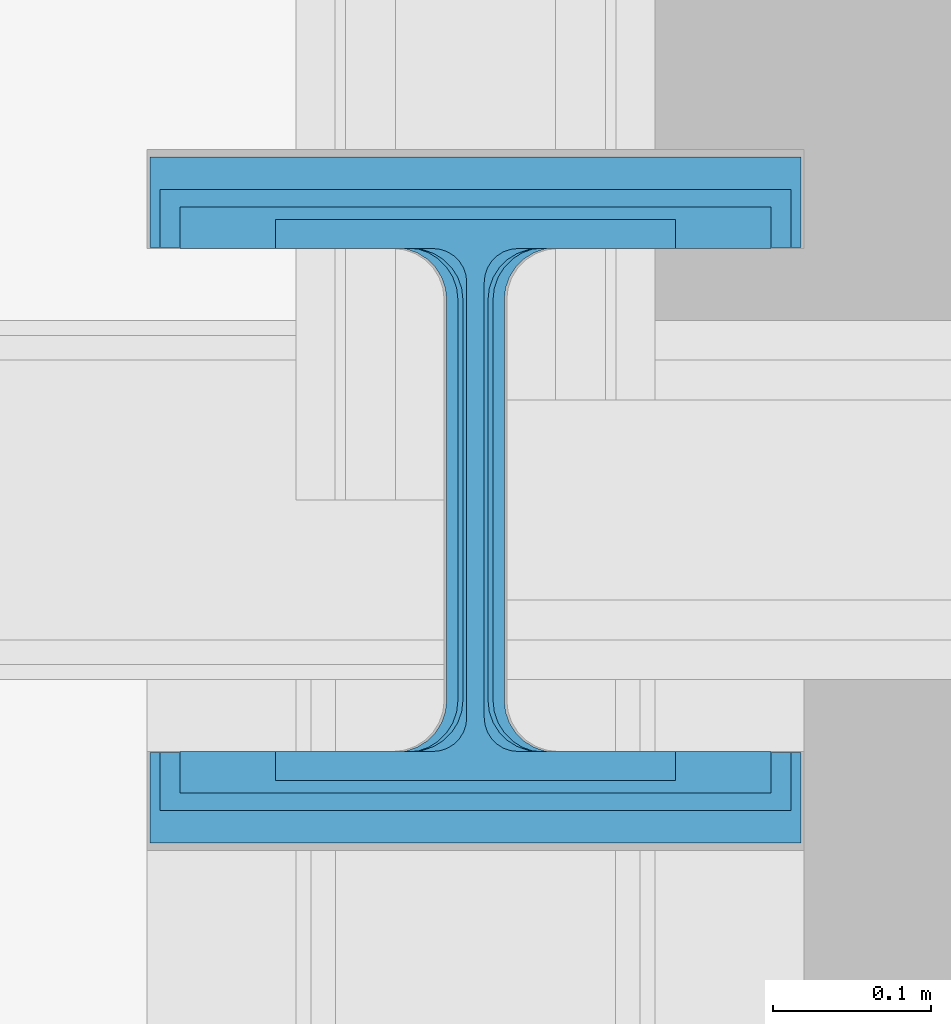
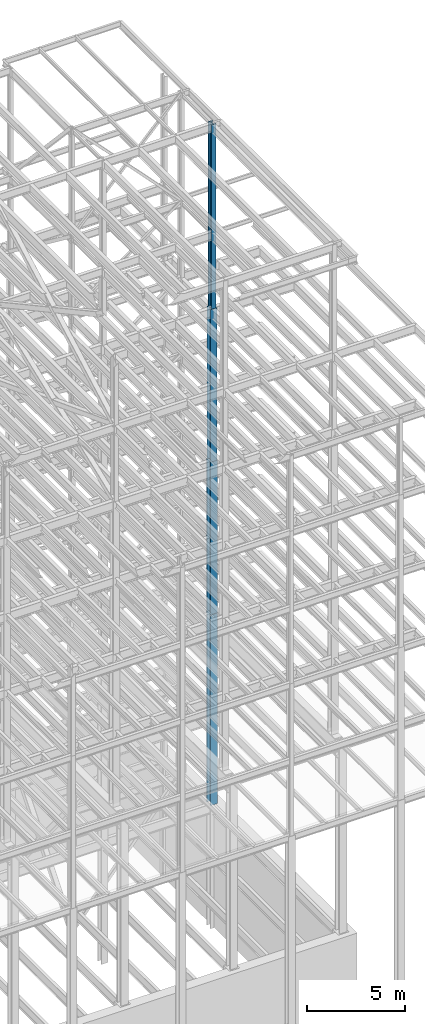
# One storey, part 112 of 150: 4 columns.
"""IFC2X3 building model written with IfcOpenShell, lengths in millimetres."""

from ifc_helpers import new_model, si_unit, frame, origin_with_axes, origin_2d_with_axis, place, context, subcontext, project, spatial, i_section, extrude, material, type_object, element, save


model = new_model("IFC2X3")

# Units and contexts
model_context = context("Model", 3, precision=1e-05, world=origin_with_axes())
body_context = subcontext(model_context, "Body", "Model", "MODEL_VIEW")
ifc_project = project(units=[si_unit("LENGTHUNIT", "METRE", prefix="MILLI"), si_unit("AREAUNIT", "SQUARE_METRE"), si_unit("VOLUMEUNIT", "CUBIC_METRE"), si_unit("MASSUNIT", "GRAM", prefix="KILO"), si_unit("TIMEUNIT", "SECOND"), si_unit("PLANEANGLEUNIT", "RADIAN"), si_unit("SOLIDANGLEUNIT", "STERADIAN"), si_unit("THERMODYNAMICTEMPERATUREUNIT", "DEGREE_CELSIUS"), si_unit("LUMINOUSINTENSITYUNIT", "LUMEN")], contexts=[model_context])

# Site, building, storey
site_placement = place(None, origin_with_axes())
site = spatial("IfcSite", under=ifc_project, at=site_placement, CompositionType="ELEMENT")
building_placement = place(site_placement, origin_with_axes())
building = spatial("IfcBuilding", under=site, at=building_placement, Name="Undefined", CompositionType="ELEMENT")
storey_placement = place(building_placement, origin_with_axes())
storey = spatial("IfcBuildingStorey", under=building, at=storey_placement, Name="Undefined", CompositionType="ELEMENT", Elevation=0.0)

# Columns
ifc_material = material(Name="STEEL/A992")
column_type_1 = type_object("IfcColumnType", Name="W14X68", PredefinedType="NOTDEFINED")
column_1_placement = place(storey_placement, frame((88595.2, 22479.0, 54483.0), z_axis=(0.0, 0.0, 1.0), x_axis=(1.0, 0.0, 0.0)))
element("IfcColumn", 1, at=column_1_placement, inside=storey, type_object=column_type_1, material=ifc_material, Name="COLUMN", ObjectType="W14X68", context=body_context, shape_type="SweptSolid", body=[
    extrude(i_section(OverallWidth=254.0, OverallDepth=355.6, WebThickness=11.1125, FlangeThickness=18.288, FilletRadius=21.3994, at=origin_2d_with_axis()), frame((0.0, 0.0, 11430.0), z_axis=(0.0, 0.0, -1.0), x_axis=(-1.0, 0.0, 0.0)), (0.0, 0.0, 1.0), 11430.0),
])
column_type_2 = type_object("IfcColumnType", Name="W14X132", PredefinedType="NOTDEFINED")
column_2_placement = place(storey_placement, frame((88595.2, 22479.0, 45034.2), z_axis=(0.0, 0.0, 1.0), x_axis=(1.0, 0.0, 0.0)))
element("IfcColumn", 2, at=column_2_placement, inside=storey, type_object=column_type_2, material=ifc_material, Name="COLUMN", ObjectType="W14X132", context=body_context, shape_type="SweptSolid", body=[
    extrude(i_section(OverallWidth=374.65, OverallDepth=371.475, WebThickness=15.875, FlangeThickness=26.162, FilletRadius=32.5755, at=origin_2d_with_axis()), frame((0.0, 0.0, 9448.8), z_axis=(0.0, 0.0, -1.0), x_axis=(-1.0, 0.0, 0.0)), (0.0, 0.0, 1.0), 9448.8),
])
column_type_3 = type_object("IfcColumnType", Name="W14X193", PredefinedType="NOTDEFINED")
column_3_placement = place(storey_placement, frame((88595.2, 22479.0, 35585.4), z_axis=(0.0, 0.0, 1.0), x_axis=(1.0, 0.0, 0.0)))
element("IfcColumn", 3, at=column_3_placement, inside=storey, type_object=column_type_3, material=ifc_material, Name="COLUMN", ObjectType="W14X193", context=body_context, shape_type="SweptSolid", body=[
    extrude(i_section(OverallWidth=400.05, OverallDepth=393.7, WebThickness=22.225, FlangeThickness=36.576, FilletRadius=33.2739, at=origin_2d_with_axis()), frame((0.0, 0.0, 9448.8), z_axis=(0.0, 0.0, -1.0), x_axis=(-1.0, 0.0, 0.0)), (0.0, 0.0, 1.0), 9448.79999999999),
])
column_type_4 = type_object("IfcColumnType", Name="W14X311", PredefinedType="NOTDEFINED")
column_4_placement = place(storey_placement, frame((88595.2, 22479.0, 23774.4), z_axis=(0.0, 0.0, 1.0), x_axis=(1.0, 0.0, 0.0)))
element("IfcColumn", 4, at=column_4_placement, inside=storey, type_object=column_type_4, material=ifc_material, Name="COLUMN", ObjectType="W14X311", context=body_context, shape_type="SweptSolid", body=[
    extrude(i_section(OverallWidth=412.75, OverallDepth=434.975, WebThickness=36.5125, FlangeThickness=57.404, FilletRadius=33.0834, at=origin_2d_with_axis()), frame((0.0, 0.0, 11811.0), z_axis=(0.0, 0.0, -1.0), x_axis=(-1.0, 0.0, 0.0)), (0.0, 0.0, 1.0), 11811.0),
])

save(model, "model.ifc")
